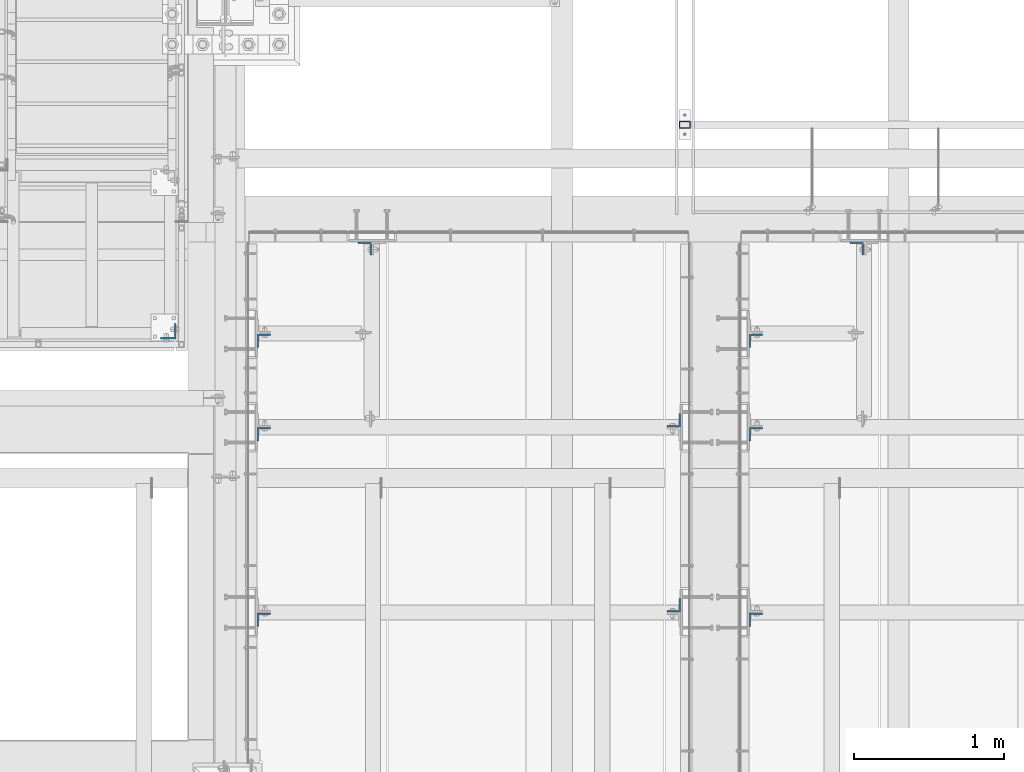
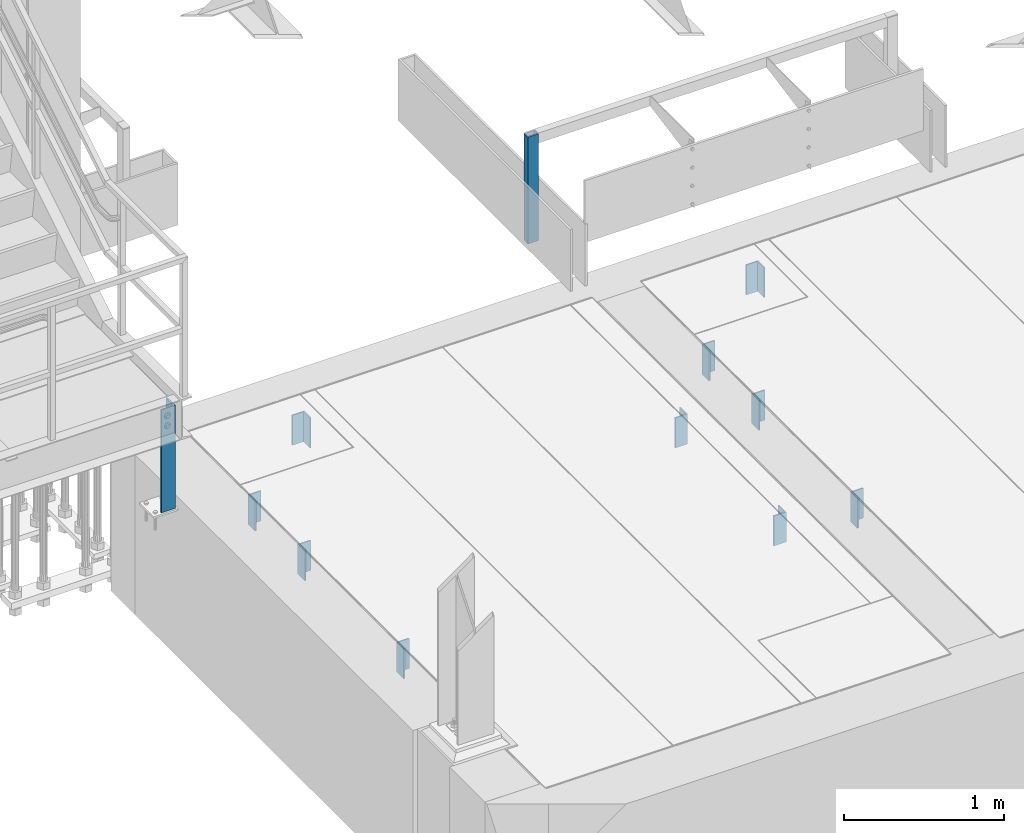
# One storey, part 1479 of 3843: 12 columns, 10 elements without a shape of their own.
"""IFC2X3 building model written with IfcOpenShell, lengths in millimetres."""

from ifc_helpers import new_model, si_unit, frame, origin_with_axes, place, context, subcontext, project, spatial, faceted_brep, material, type_object, element, aggregate, save


model = new_model("IFC2X3")

# Units and contexts
model_context = context("Model", 3, precision=1e-05, world=origin_with_axes())
body_context = subcontext(model_context, "Body", "Model", "MODEL_VIEW")
ifc_project = project(units=[si_unit("LENGTHUNIT", "METRE", prefix="MILLI"), si_unit("AREAUNIT", "SQUARE_METRE"), si_unit("VOLUMEUNIT", "CUBIC_METRE"), si_unit("MASSUNIT", "GRAM", prefix="KILO"), si_unit("TIMEUNIT", "SECOND"), si_unit("PLANEANGLEUNIT", "RADIAN"), si_unit("SOLIDANGLEUNIT", "STERADIAN"), si_unit("THERMODYNAMICTEMPERATUREUNIT", "DEGREE_CELSIUS"), si_unit("LUMINOUSINTENSITYUNIT", "LUMEN")], contexts=[model_context])

# Site, building, storey
site_placement = place(None, origin_with_axes())
site = spatial("IfcSite", under=ifc_project, at=site_placement, CompositionType="ELEMENT")
building_placement = place(site_placement, origin_with_axes())
building = spatial("IfcBuilding", under=site, at=building_placement, Name="Undefined", CompositionType="ELEMENT")
storey_placement = place(building_placement, origin_with_axes())
storey = spatial("IfcBuildingStorey", under=building, at=storey_placement, Name="Undefined", CompositionType="ELEMENT", Elevation=0.0)

# Assembly, column
assembly_1_placement = place(storey_placement, origin_with_axes())
assembly_1 = element("IfcElementAssembly", 1, at=assembly_1_placement, inside=storey, Name="FRAME", AssemblyPlace="NOTDEFINED", PredefinedType="RIGID_FRAME")
ifc_material_1 = material()
column_type_1 = type_object("IfcColumnType", Name="HSS3X2X1/4", PredefinedType="NOTDEFINED")
column_1_placement = place(assembly_1_placement, frame((58983.5450197567, 19468.65786883, 30486.35), z_axis=(1.0, 0.0, 0.0), x_axis=(0.0, 0.0, 1.0)))
column_1 = element("IfcColumn", 2, at=column_1_placement, type_object=column_type_1, material=ifc_material_1, Name="POST", ObjectType="HSS3X2X1/4", context=body_context, shape_type="Brep", body=[
    faceted_brep([(0.0, 19.0500000000029, -31.75), (0.0, -19.0500000000029, -31.75), (812.800000000007, -19.0500000000029, -31.75), (812.800000000007, 19.0500000000029, -31.75), (0.0, -19.0500000000029, 31.75), (812.800000000007, -19.0500000000029, 31.75), (0.0, 19.0500000000029, 31.75), (812.800000000007, 19.0500000000029, 31.75), (0.0, 25.4000000000015, -38.0999999999985), (0.0, 25.4000000000015, 38.0999999999985), (812.800000000007, 25.4000000000015, 38.0999999999985), (812.800000000007, 25.4000000000015, -38.0999999999985), (0.0, -25.4000000000015, 38.0999999999985), (812.800000000007, -25.4000000000015, 38.0999999999985), (0.0, -25.4000000000015, -38.0999999999985), (812.800000000007, -25.4000000000015, -38.0999999999985)], [[[0, 1, 2, 3]], [[1, 4, 5, 2]], [[4, 6, 7, 5]], [[6, 0, 3, 7]], [[8, 9, 10, 11]], [[9, 12, 13, 10]], [[12, 14, 15, 13]], [[14, 8, 11, 15]], [[13, 15, 11, 10], [5, 7, 3, 2]], [[14, 12, 9, 8], [6, 4, 1, 0]]]),
])
aggregate(assembly_1, [column_1])

assembly_2_placement = place(storey_placement, origin_with_axes())
assembly_2 = element("IfcElementAssembly", 3, at=assembly_2_placement, inside=storey, Name="POST", AssemblyPlace="NOTDEFINED", PredefinedType="RIGID_FRAME")
ifc_material_2 = material(Name="STEEL/A36")
column_type_2 = type_object("IfcColumnType", Name="L4X4X3/8", PredefinedType="NOTDEFINED")
column_2_placement = place(assembly_2_placement, frame((55549.7999999891, 18097.500000064, 30479.9999999948), z_axis=(0.0, 1.0, 0.0), x_axis=(0.0, 0.0, 1.0)))
column_2 = element("IfcColumn", 4, at=column_2_placement, type_object=column_type_2, material=ifc_material_2, Name="POST", ObjectType="L4X4X3/8", context=body_context, shape_type="Brep", body=[
    faceted_brep([(12.7000000000007, 50.7999999999993, -50.8000000000029), (12.7000000000007, 50.7999999999993, 50.8000000000029), (796.192307094392, 50.8000000000029, 50.7999999999993), (796.192307094392, 50.8000000000029, -50.7999999999993), (12.7000000051848, 41.2750000000015, 50.7999999999993), (796.192307094392, 41.2750000000015, 50.7999999999993), (12.7000000000007, 41.2750000000015, -41.2750000000015), (796.192307094392, 41.2750000000015, -41.2750000000015), (12.7000000051848, -50.8000000000029, -41.2750000000015), (796.192307094392, -50.8000000000029, -41.2750000000015), (12.7000000000007, -50.7999999999993, -50.8000000000029), (796.192307094392, -50.8000000000029, -50.7999999999993)], [[[0, 1, 2, 3]], [[1, 4, 5, 2]], [[4, 6, 7, 5]], [[6, 8, 9, 7]], [[8, 10, 11, 9]], [[10, 0, 3, 11]], [[5, 7, 9, 11, 3, 2]], [[10, 8, 6, 4, 1, 0]]]),
])
aggregate(assembly_2, [column_2])

assembly_3_placement = place(storey_placement, origin_with_axes())
assembly_3 = element("IfcElementAssembly", 5, at=assembly_3_placement, inside=storey, Name="BEAM", AssemblyPlace="NOTDEFINED", PredefinedType="RIGID_FRAME")
column_type_3 = type_object("IfcColumnType", Name="L3-1/2X3-1/2X3/8", PredefinedType="NOTDEFINED")
column_3_placement = place(assembly_3_placement, frame((58908.9499969482, 17506.95, 30162.5), z_axis=(0.0, 1.0, 0.0), x_axis=(0.0, 0.0, 1.0)))
column_3 = element("IfcColumn", 6, at=column_3_placement, type_object=column_type_3, material=ifc_material_2, Name="ANGLE", ObjectType="L3-1/2X3-1/2X3/8", context=body_context, shape_type="Brep", body=[
    faceted_brep([(-3.63797880709171e-12, 44.4499999999971, -44.4500000000007), (-3.63797880709171e-12, 44.4499999999971, 44.4500000000007), (228.600000000006, 44.4499999999971, 44.4500000000007), (228.600000000006, 44.4499999999971, -44.4500000000007), (0.0, 34.9250000000029, 44.4500000000007), (228.600000000006, 34.9250000000029, 44.4500000000007), (0.0, 34.9250000000029, -34.9250000000029), (228.600000000006, 34.9250000000029, -34.9249999999993), (0.0, -44.4499999999971, -34.9249999999993), (228.600000000006, -44.4499999999971, -34.9249999999993), (3.63797880709171e-12, -44.4499999999971, -44.4500000000007), (228.600000000006, -44.4499999999971, -44.4500000000007)], [[[0, 1, 2, 3]], [[1, 4, 5, 2]], [[4, 6, 7, 5]], [[6, 8, 9, 7]], [[8, 10, 11, 9]], [[10, 0, 3, 11]], [[5, 7, 9, 11, 3, 2]], [[10, 8, 6, 4, 1, 0]]]),
])

assembly_4_placement = place(storey_placement, origin_with_axes())
assembly_4 = element("IfcElementAssembly", 7, at=assembly_4_placement, inside=storey, Name="BEAM", AssemblyPlace="NOTDEFINED", PredefinedType="RIGID_FRAME")
column_4_placement = place(assembly_4_placement, frame((58908.9499969482, 16276.6375, 30162.5), z_axis=(0.0, 1.0, 0.0), x_axis=(0.0, 0.0, 1.0)))
column_4 = element("IfcColumn", 8, at=column_4_placement, type_object=column_type_3, material=ifc_material_2, Name="ANGLE", ObjectType="L3-1/2X3-1/2X3/8", context=body_context, shape_type="Brep", body=[
    faceted_brep([(-3.63797880709171e-12, 44.4499999999971, -44.4500000000007), (-3.63797880709171e-12, 44.4499999999971, 44.4500000000007), (228.600000000006, 44.4499999999971, 44.4500000000007), (228.600000000006, 44.4499999999971, -44.4500000000007), (0.0, 34.9250000000029, 44.4500000000007), (228.600000000006, 34.9250000000029, 44.4500000000007), (0.0, 34.9250000000029, -34.9250000000029), (228.600000000006, 34.9250000000029, -34.9249999999993), (0.0, -44.4499999999971, -34.9249999999993), (228.600000000006, -44.4499999999971, -34.9249999999993), (3.63797880709171e-12, -44.4499999999971, -44.4500000000007), (228.600000000006, -44.4499999999971, -44.4500000000007)], [[[0, 1, 2, 3]], [[1, 4, 5, 2]], [[4, 6, 7, 5]], [[6, 8, 9, 7]], [[8, 10, 11, 9]], [[10, 0, 3, 11]], [[5, 7, 9, 11, 3, 2]], [[10, 8, 6, 4, 1, 0]]]),
])

assembly_5_placement = place(storey_placement, origin_with_axes())
assembly_5 = element("IfcElementAssembly", 9, at=assembly_5_placement, inside=storey, Name="BEAM", AssemblyPlace="NOTDEFINED", PredefinedType="RIGID_FRAME")
column_5_placement = place(assembly_5_placement, frame((56184.8000030518, 18034.0, 30162.5), z_axis=(0.0, -1.0, 0.0), x_axis=(0.0, 0.0, 1.0)))
column_5 = element("IfcColumn", 10, at=column_5_placement, type_object=column_type_3, material=ifc_material_2, Name="ANGLE", ObjectType="L3-1/2X3-1/2X3/8", context=body_context, shape_type="Brep", body=[
    faceted_brep([(-3.63797880709171e-12, 44.4499999999971, -44.4500000000007), (-3.63797880709171e-12, 44.4499999999971, 44.4500000000007), (228.600000000006, 44.4499999999971, 44.4500000000007), (228.600000000006, 44.4499999999971, -44.4500000000007), (0.0, 34.9250000000029, 44.4500000000007), (228.600000000006, 34.9250000000029, 44.4500000000007), (0.0, 34.9250000000029, -34.9250000000029), (228.600000000006, 34.9250000000029, -34.9249999999993), (0.0, -44.4499999999971, -34.9249999999993), (228.600000000006, -44.4499999999971, -34.9249999999993), (3.63797880709171e-12, -44.4499999999971, -44.4500000000007), (228.600000000006, -44.4499999999971, -44.4500000000007)], [[[0, 1, 2, 3]], [[1, 4, 5, 2]], [[4, 6, 7, 5]], [[6, 8, 9, 7]], [[8, 10, 11, 9]], [[10, 0, 3, 11]], [[5, 7, 9, 11, 3, 2]], [[10, 8, 6, 4, 1, 0]]]),
])
aggregate(assembly_5, [column_5])

# Column
column_6_placement = place(assembly_3_placement, frame((56184.8000030518, 17411.7, 30162.5), z_axis=(0.0, -1.0, 0.0), x_axis=(0.0, 0.0, 1.0)))
column_6 = element("IfcColumn", 11, at=column_6_placement, type_object=column_type_3, material=ifc_material_2, Name="ANGLE", ObjectType="L3-1/2X3-1/2X3/8", context=body_context, shape_type="Brep", body=[
    faceted_brep([(-3.63797880709171e-12, 44.4499999999971, -44.4500000000007), (-3.63797880709171e-12, 44.4499999999971, 44.4500000000007), (228.600000000006, 44.4499999999971, 44.4500000000007), (228.600000000006, 44.4499999999971, -44.4500000000007), (0.0, 34.9250000000029, 44.4500000000007), (228.600000000006, 34.9250000000029, 44.4500000000007), (0.0, 34.9250000000029, -34.9250000000029), (228.600000000006, 34.9250000000029, -34.9249999999993), (0.0, -44.4499999999971, -34.9249999999993), (228.600000000006, -44.4499999999971, -34.9249999999993), (3.63797880709171e-12, -44.4499999999971, -44.4500000000007), (228.600000000006, -44.4499999999971, -44.4500000000007)], [[[0, 1, 2, 3]], [[1, 4, 5, 2]], [[4, 6, 7, 5]], [[6, 8, 9, 7]], [[8, 10, 11, 9]], [[10, 0, 3, 11]], [[5, 7, 9, 11, 3, 2]], [[10, 8, 6, 4, 1, 0]]]),
])

aggregate(assembly_3, [column_3, column_6])

column_7_placement = place(assembly_4_placement, frame((56184.8000030518, 16181.3875, 30162.5), z_axis=(0.0, -1.0, 0.0), x_axis=(0.0, 0.0, 1.0)))
column_7 = element("IfcColumn", 12, at=column_7_placement, type_object=column_type_3, material=ifc_material_2, Name="ANGLE", ObjectType="L3-1/2X3-1/2X3/8", context=body_context, shape_type="Brep", body=[
    faceted_brep([(-3.63797880709171e-12, 44.4499999999971, -44.4500000000007), (-3.63797880709171e-12, 44.4499999999971, 44.4500000000007), (228.600000000006, 44.4499999999971, 44.4500000000007), (228.600000000006, 44.4499999999971, -44.4500000000007), (0.0, 34.9250000000029, 44.4500000000007), (228.600000000006, 34.9250000000029, 44.4500000000007), (0.0, 34.9250000000029, -34.9250000000029), (228.600000000006, 34.9250000000029, -34.9249999999993), (0.0, -44.4499999999971, -34.9249999999993), (228.600000000006, -44.4499999999971, -34.9249999999993), (3.63797880709171e-12, -44.4499999999971, -44.4500000000007), (228.600000000006, -44.4499999999971, -44.4500000000007)], [[[0, 1, 2, 3]], [[1, 4, 5, 2]], [[4, 6, 7, 5]], [[6, 8, 9, 7]], [[8, 10, 11, 9]], [[10, 0, 3, 11]], [[5, 7, 9, 11, 3, 2]], [[10, 8, 6, 4, 1, 0]]]),
])

aggregate(assembly_4, [column_4, column_7])

# Assembly, column
assembly_6_placement = place(storey_placement, origin_with_axes())
assembly_6 = element("IfcElementAssembly", 13, at=assembly_6_placement, inside=storey, Name="BEAM", AssemblyPlace="NOTDEFINED", PredefinedType="RIGID_FRAME")
column_8_placement = place(assembly_6_placement, frame((59455.0500030518, 16181.3875, 30162.5), z_axis=(0.0, -1.0, 0.0), x_axis=(0.0, 0.0, 1.0)))
column_8 = element("IfcColumn", 14, at=column_8_placement, type_object=column_type_3, material=ifc_material_2, Name="ANGLE", ObjectType="L3-1/2X3-1/2X3/8", context=body_context, shape_type="Brep", body=[
    faceted_brep([(-3.63797880709171e-12, 44.4499999999971, -44.4500000000007), (-3.63797880709171e-12, 44.4499999999971, 44.4500000000007), (228.600000000006, 44.4499999999971, 44.4500000000007), (228.600000000006, 44.4499999999971, -44.4500000000007), (0.0, 34.9250000000029, 44.4500000000007), (228.600000000006, 34.9250000000029, 44.4500000000007), (0.0, 34.9250000000029, -34.9250000000029), (228.600000000006, 34.9250000000029, -34.9249999999993), (0.0, -44.4499999999971, -34.9249999999993), (228.600000000006, -44.4499999999971, -34.9249999999993), (3.63797880709171e-12, -44.4499999999971, -44.4500000000007), (228.600000000006, -44.4499999999971, -44.4500000000007)], [[[0, 1, 2, 3]], [[1, 4, 5, 2]], [[4, 6, 7, 5]], [[6, 8, 9, 7]], [[8, 10, 11, 9]], [[10, 0, 3, 11]], [[5, 7, 9, 11, 3, 2]], [[10, 8, 6, 4, 1, 0]]]),
])
aggregate(assembly_6, [column_8])

assembly_7_placement = place(storey_placement, origin_with_axes())
assembly_7 = element("IfcElementAssembly", 15, at=assembly_7_placement, inside=storey, Name="BEAM", AssemblyPlace="NOTDEFINED", PredefinedType="RIGID_FRAME")
column_9_placement = place(assembly_7_placement, frame((59455.0500030518, 17411.7, 30162.5), z_axis=(0.0, -1.0, 0.0), x_axis=(0.0, 0.0, 1.0)))
column_9 = element("IfcColumn", 16, at=column_9_placement, type_object=column_type_3, material=ifc_material_2, Name="ANGLE", ObjectType="L3-1/2X3-1/2X3/8", context=body_context, shape_type="Brep", body=[
    faceted_brep([(-3.63797880709171e-12, 44.4499999999971, -44.4500000000007), (-3.63797880709171e-12, 44.4499999999971, 44.4500000000007), (228.600000000006, 44.4499999999971, 44.4500000000007), (228.600000000006, 44.4499999999971, -44.4500000000007), (0.0, 34.9250000000029, 44.4500000000007), (228.600000000006, 34.9250000000029, 44.4500000000007), (0.0, 34.9250000000029, -34.9250000000029), (228.600000000006, 34.9250000000029, -34.9249999999993), (0.0, -44.4499999999971, -34.9249999999993), (228.600000000006, -44.4499999999971, -34.9249999999993), (3.63797880709171e-12, -44.4499999999971, -44.4500000000007), (228.600000000006, -44.4499999999971, -44.4500000000007)], [[[0, 1, 2, 3]], [[1, 4, 5, 2]], [[4, 6, 7, 5]], [[6, 8, 9, 7]], [[8, 10, 11, 9]], [[10, 0, 3, 11]], [[5, 7, 9, 11, 3, 2]], [[10, 8, 6, 4, 1, 0]]]),
])
aggregate(assembly_7, [column_9])

assembly_8_placement = place(storey_placement, origin_with_axes())
assembly_8 = element("IfcElementAssembly", 17, at=assembly_8_placement, inside=storey, Name="BEAM", AssemblyPlace="NOTDEFINED", PredefinedType="RIGID_FRAME")
column_10_placement = place(assembly_8_placement, frame((59455.0500030518, 18034.0, 30162.5), z_axis=(0.0, -1.0, 0.0), x_axis=(0.0, 0.0, 1.0)))
column_10 = element("IfcColumn", 18, at=column_10_placement, type_object=column_type_3, material=ifc_material_2, Name="ANGLE", ObjectType="L3-1/2X3-1/2X3/8", context=body_context, shape_type="Brep", body=[
    faceted_brep([(-3.63797880709171e-12, 44.4499999999971, -44.4500000000007), (-3.63797880709171e-12, 44.4499999999971, 44.4500000000007), (228.600000000006, 44.4499999999971, 44.4500000000007), (228.600000000006, 44.4499999999971, -44.4500000000007), (0.0, 34.9250000000029, 44.4500000000007), (228.600000000006, 34.9250000000029, 44.4500000000007), (0.0, 34.9250000000029, -34.9250000000029), (228.600000000006, 34.9250000000029, -34.9249999999993), (0.0, -44.4499999999971, -34.9249999999993), (228.600000000006, -44.4499999999971, -34.9249999999993), (3.63797880709171e-12, -44.4499999999971, -44.4500000000007), (228.600000000006, -44.4499999999971, -44.4500000000007)], [[[0, 1, 2, 3]], [[1, 4, 5, 2]], [[4, 6, 7, 5]], [[6, 8, 9, 7]], [[8, 10, 11, 9]], [[10, 0, 3, 11]], [[5, 7, 9, 11, 3, 2]], [[10, 8, 6, 4, 1, 0]]]),
])
aggregate(assembly_8, [column_10])

assembly_9_placement = place(storey_placement, origin_with_axes())
assembly_9 = element("IfcElementAssembly", 19, at=assembly_9_placement, inside=storey, Name="BEAM", AssemblyPlace="NOTDEFINED", PredefinedType="RIGID_FRAME")
column_11_placement = place(assembly_9_placement, frame((60124.975, 18646.7749969483, 30162.5), z_axis=(-1.0, 0.0, 0.0), x_axis=(0.0, 0.0, 1.0)))
column_11 = element("IfcColumn", 20, at=column_11_placement, type_object=column_type_3, material=ifc_material_2, Name="ANGLE", ObjectType="L3-1/2X3-1/2X3/8", context=body_context, shape_type="Brep", body=[
    faceted_brep([(-3.63797880709171e-12, 44.4499999999971, -44.4500000000007), (-3.63797880709171e-12, 44.4499999999971, 44.4500000000007), (228.600000000006, 44.4499999999971, 44.4500000000007), (228.600000000006, 44.4499999999971, -44.4500000000007), (0.0, 34.9250000000029, 44.4500000000007), (228.600000000006, 34.9250000000029, 44.4500000000007), (0.0, 34.9250000000029, -34.9250000000029), (228.600000000006, 34.9250000000029, -34.9249999999993), (0.0, -44.4499999999971, -34.9249999999993), (228.600000000006, -44.4499999999971, -34.9249999999993), (3.63797880709171e-12, -44.4499999999971, -44.4500000000007), (228.600000000006, -44.4499999999971, -44.4500000000007)], [[[0, 1, 2, 3]], [[1, 4, 5, 2]], [[4, 6, 7, 5]], [[6, 8, 9, 7]], [[8, 10, 11, 9]], [[10, 0, 3, 11]], [[5, 7, 9, 11, 3, 2]], [[10, 8, 6, 4, 1, 0]]]),
])
aggregate(assembly_9, [column_11])

assembly_10_placement = place(storey_placement, origin_with_axes())
assembly_10 = element("IfcElementAssembly", 21, at=assembly_10_placement, inside=storey, Name="BEAM", AssemblyPlace="NOTDEFINED", PredefinedType="RIGID_FRAME")
column_12_placement = place(assembly_10_placement, frame((56854.725, 18646.775, 30162.5), z_axis=(-1.0, 0.0, 0.0), x_axis=(0.0, 0.0, 1.0)))
column_12 = element("IfcColumn", 22, at=column_12_placement, type_object=column_type_3, material=ifc_material_2, Name="ANGLE", ObjectType="L3-1/2X3-1/2X3/8", context=body_context, shape_type="Brep", body=[
    faceted_brep([(-3.63797880709171e-12, 44.4499999999971, -44.4500000000007), (-3.63797880709171e-12, 44.4499999999971, 44.4500000000007), (228.600000000006, 44.4499999999971, 44.4500000000007), (228.600000000006, 44.4499999999971, -44.4500000000007), (0.0, 34.9250000000029, 44.4500000000007), (228.600000000006, 34.9250000000029, 44.4500000000007), (0.0, 34.9250000000029, -34.9250000000029), (228.600000000006, 34.9250000000029, -34.9249999999993), (0.0, -44.4499999999971, -34.9249999999993), (228.600000000006, -44.4499999999971, -34.9249999999993), (3.63797880709171e-12, -44.4499999999971, -44.4500000000007), (228.600000000006, -44.4499999999971, -44.4500000000007)], [[[0, 1, 2, 3]], [[1, 4, 5, 2]], [[4, 6, 7, 5]], [[6, 8, 9, 7]], [[8, 10, 11, 9]], [[10, 0, 3, 11]], [[5, 7, 9, 11, 3, 2]], [[10, 8, 6, 4, 1, 0]]]),
])
aggregate(assembly_10, [column_12])

save(model, "model.ifc")
